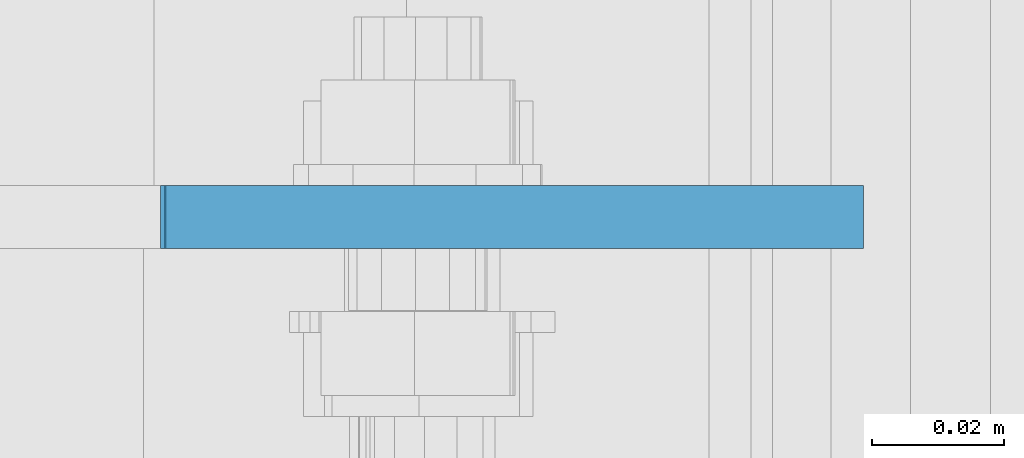
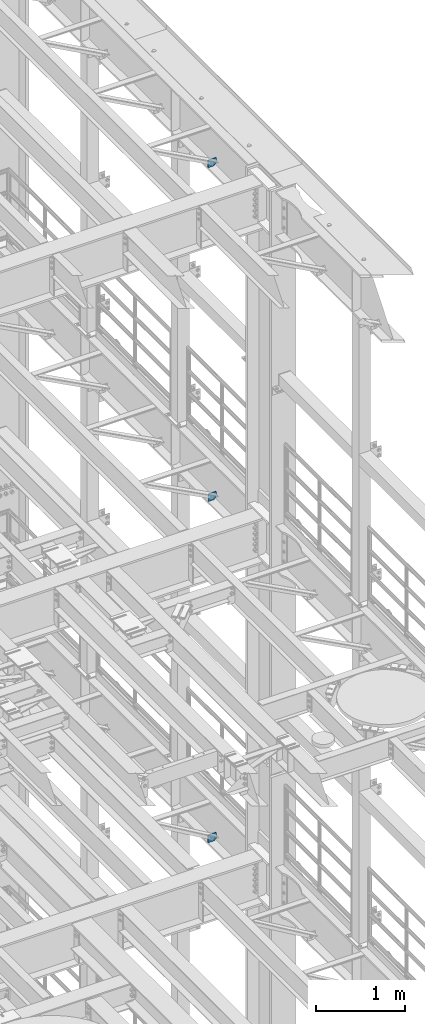
# One storey, part 1740 of 1876: 3 plates, 3 elements without a shape of their own.
"""IFC2X3 building model written with IfcOpenShell, lengths in millimetres."""

from ifc_helpers import new_model, si_unit, frame, origin_with_axes, place, context, subcontext, project, spatial, faceted_brep, material, type_object, element, aggregate, save


model = new_model("IFC2X3")

# Units and contexts
model_context = context("Model", 3, precision=1e-05, world=origin_with_axes())
body_context = subcontext(model_context, "Body", "Model", "MODEL_VIEW")
ifc_project = project(units=[si_unit("LENGTHUNIT", "METRE", prefix="MILLI"), si_unit("AREAUNIT", "SQUARE_METRE"), si_unit("VOLUMEUNIT", "CUBIC_METRE"), si_unit("MASSUNIT", "GRAM", prefix="KILO"), si_unit("TIMEUNIT", "SECOND"), si_unit("PLANEANGLEUNIT", "RADIAN"), si_unit("SOLIDANGLEUNIT", "STERADIAN"), si_unit("THERMODYNAMICTEMPERATUREUNIT", "DEGREE_CELSIUS"), si_unit("LUMINOUSINTENSITYUNIT", "LUMEN")], contexts=[model_context])

# Site, building, storey
site_placement = place(None, origin_with_axes())
site = spatial("IfcSite", under=ifc_project, at=site_placement, CompositionType="ELEMENT")
building_placement = place(site_placement, origin_with_axes())
building = spatial("IfcBuilding", under=site, at=building_placement, Name="Undefined", CompositionType="ELEMENT")
storey_placement = place(building_placement, origin_with_axes())
storey = spatial("IfcBuildingStorey", under=building, at=storey_placement, Name="Undefined", CompositionType="ELEMENT", Elevation=0.0)

# Assembly, plate
assembly_1_placement = place(storey_placement, origin_with_axes())
assembly_1 = element("IfcElementAssembly", 1, at=assembly_1_placement, inside=storey, Name="BEAM", AssemblyPlace="NOTDEFINED", PredefinedType="RIGID_FRAME")
ifc_material = material(Name="STEEL/A36")
plate_type_1 = type_object("IfcPlateType", PredefinedType="NOTDEFINED")
plate_1_placement = place(assembly_1_placement, frame((7612.85625, 8834.4375, 21958.3), z_axis=(0.0, 0.0, 1.0), x_axis=(-1.0, 0.0, 0.0)))
plate_1 = element("IfcPlate", 2, at=plate_1_placement, type_object=plate_type_1, material=ifc_material, Name="PLATE", context=body_context, shape_type="Brep", body=[
    faceted_brep([(-9.76996261670138e-14, -4.76250000000073, 31.75), (-3.4106151360902e-06, -4.76249999999982, 104.420860290527), (-3.4106151360902e-06, 4.76249999999982, 104.420860290527), (-9.76996261670138e-14, 4.76250000000073, 31.75), (105.552177429199, -4.76249999999982, 104.420860290527), (105.552177429199, 4.76249999999982, 104.420860290527), (105.552177429199, -4.76249999999982, 0.0), (105.552177429199, 4.76249999999982, 0.0), (31.75, -4.76250000000073, 0.0), (31.75, 4.76250000000073, 0.0)], [[[0, 1, 2, 3]], [[1, 4, 5, 2]], [[4, 6, 7, 5]], [[6, 8, 9, 7]], [[8, 0, 3, 9]], [[5, 7, 9, 3, 2]], [[8, 6, 4, 1, 0]]]),
])
aggregate(assembly_1, [plate_1])

assembly_2_placement = place(storey_placement, origin_with_axes())
assembly_2 = element("IfcElementAssembly", 3, at=assembly_2_placement, inside=storey, Name="BEAM", AssemblyPlace="NOTDEFINED", PredefinedType="RIGID_FRAME")
plate_type_2 = type_object("IfcPlateType", PredefinedType="NOTDEFINED")
plate_2_placement = place(assembly_2_placement, frame((7612.85625021727, 8834.43749999999, 12819.726415621), z_axis=(0.0, 0.0, -1.0), x_axis=(-1.0, 0.0, 0.0)))
plate_2 = element("IfcPlate", 4, at=plate_2_placement, type_object=plate_type_2, material=ifc_material, Name="PLATE", context=body_context, shape_type="Brep", body=[
    faceted_brep([(0.0, -4.76249999999982, 0.0), (-3.57139560946962e-06, -4.76249999999982, 81.6264114379865), (-3.57139560946962e-06, 4.76249999999982, 81.6264114379865), (0.0, 4.76249999999982, 0.0), (25.3999958038776, -4.76249999999982, 107.026412963854), (25.3999958038776, 4.76249999999982, 107.026412963854), (106.188095092818, -4.76249999999982, 107.02641296382), (106.188095092818, 4.76249999999982, 107.02641296382), (106.188095092773, -4.76249999999982, -7.27595761418343e-11), (106.188095092773, 4.76249999999982, -7.27595761418343e-11)], [[[0, 1, 2, 3]], [[1, 4, 5, 2]], [[4, 6, 7, 5]], [[6, 8, 9, 7]], [[8, 0, 3, 9]], [[5, 7, 9, 3, 2]], [[8, 6, 4, 1, 0]]]),
])
aggregate(assembly_2, [plate_2])

assembly_3_placement = place(storey_placement, origin_with_axes())
assembly_3 = element("IfcElementAssembly", 5, at=assembly_3_placement, inside=storey, Name="BEAM", AssemblyPlace="NOTDEFINED", PredefinedType="RIGID_FRAME")
plate_type_3 = type_object("IfcPlateType", PredefinedType="NOTDEFINED")
plate_3_placement = place(assembly_3_placement, frame((7612.85625000072, 8834.4375, 17386.2999999996), z_axis=(-1.0, 0.0, 0.0), x_axis=(0.0, 0.0, 1.0)))
plate_3 = element("IfcPlate", 6, at=plate_3_placement, type_object=plate_type_3, material=ifc_material, Name="PLATE", context=body_context, shape_type="Brep", body=[
    faceted_brep([(-9.76996261670138e-14, -4.76250000000073, 31.75), (0.0, -4.76249999999982, 105.281791687012), (0.0, 4.76249999999982, 105.281791687012), (-9.76996261670138e-14, 4.76250000000073, 31.75), (103.391876220703, -4.76249999999982, 105.281791687012), (103.391876220703, 4.76249999999982, 105.281791687012), (103.391876220703, -4.76249999999982, 0.0), (103.391876220703, 4.76249999999982, 0.0), (31.75, -4.76250000000073, 0.0), (31.75, 4.76250000000073, 0.0)], [[[0, 1, 2, 3]], [[1, 4, 5, 2]], [[4, 6, 7, 5]], [[6, 8, 9, 7]], [[8, 0, 3, 9]], [[5, 7, 9, 3, 2]], [[8, 6, 4, 1, 0]]]),
])
aggregate(assembly_3, [plate_3])

save(model, "model.ifc")
